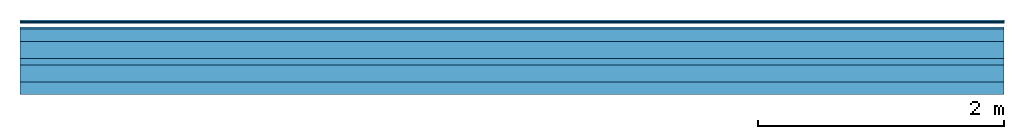
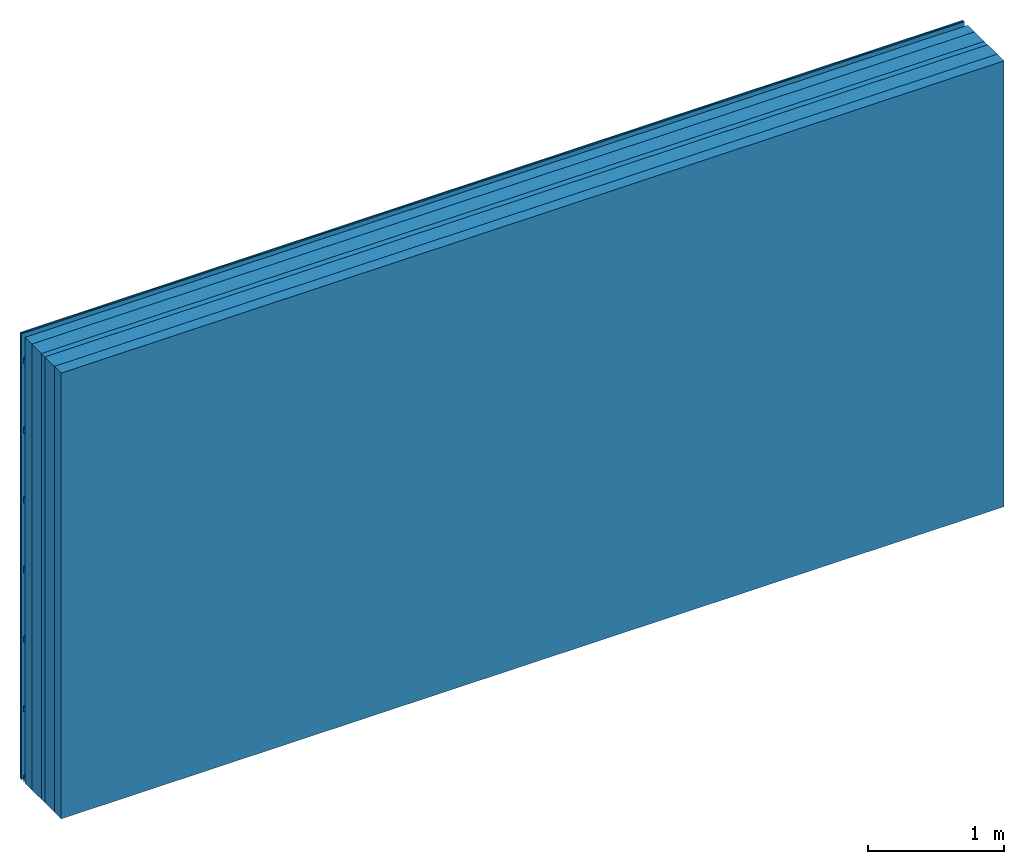
# One storey: 5 plates, 3 members, 1 element without a shape of its own.
"""IFC4 building model written with IfcOpenShell, lengths in metres."""

from ifc_helpers import new_model, si_unit, derived_unit, direction, frame, frame_2d, origin, origin_with_axes, place, context, project, spatial, polyline, rectangle, outline, extrude, material, layer, layer_set, type_object, element, aggregate, save


model = new_model("IFC4")

# Units and contexts
plan_context = context("Plan", 3, precision=1e-05, world=origin(), true_north=direction((0.0, 1.0)))
model_context = context("Model", 3, precision=1e-05, world=origin(), true_north=direction((0.0, 1.0)))
ifc_project = project(units=[si_unit("LENGTHUNIT", "METRE"), derived_unit("SOUNDPRESSUREUNIT", [(si_unit("PRESSUREUNIT", "PASCAL", prefix="MICRO"), 0)]), si_unit("ENERGYUNIT", "JOULE", prefix="MEGA"), si_unit("MASSUNIT", "GRAM", prefix="KILO"), derived_unit("THERMALTRANSMITTANCEUNIT", [(si_unit("POWERUNIT", "WATT"), 1), (si_unit("AREAUNIT", "SQUARE_METRE"), -1), (si_unit("THERMODYNAMICTEMPERATUREUNIT", "KELVIN"), -1)]), derived_unit("AREADENSITYUNIT", [(si_unit("MASSUNIT", "GRAM", prefix="KILO"), 1), (si_unit("AREAUNIT", "SQUARE_METRE"), -1)]), derived_unit("USERDEFINED", [(si_unit("ENERGYUNIT", "JOULE", prefix="MEGA"), 1), (si_unit("AREAUNIT", "SQUARE_METRE"), -1)])], contexts=[plan_context, model_context])

# Site, building, storey
site = spatial("IfcSite", under=ifc_project)
building_placement = place(None, origin())
building = spatial("IfcBuilding", under=site, at=building_placement)
storey_placement = place(building_placement, origin())
storey = spatial("IfcBuildingStorey", under=building, at=storey_placement)

# Wall, members, plates
ifc_material_1 = material(Name="Glued joints")
ifc_layer_1 = layer(ifc_material_1, 0.0, Name="Surface")
ifc_material_2 = material(Category="03.008")
ifc_layer_2 = layer(ifc_material_2, 0.0125, Name="Cover 2nd layer")
ifc_layer_3 = layer(ifc_material_2, 0.0125, Name="Cover 1st layer")
ifc_layer_4 = layer(None, 0.05, Name="Battens / profiles")
ifc_layer_5 = layer(None, 0.1, Name="Support")
ifc_material_3 = material(Name="of the art")
ifc_layer_6 = layer(ifc_material_3, 0.0, Name="Bond")
ifc_material_4 = material(Category="10.008")
ifc_layer_7 = layer(ifc_material_4, 0.14, Name="Intermediate insulation")
ifc_material_5 = material(Name="Air")
ifc_layer_8 = layer(ifc_material_5, 0.05, Name="Air gap")
ifc_layer_9 = layer(ifc_material_4, 0.14, Name="Intermediate insulation")
ifc_layer_10 = layer(ifc_material_3, 0.0, Name="Bond")
ifc_layer_11 = layer(None, 0.1, Name="Support")
ifc_layer_set = layer_set([ifc_layer_1, ifc_layer_2, ifc_layer_3, ifc_layer_4, ifc_layer_5, ifc_layer_6, ifc_layer_7, ifc_layer_8, ifc_layer_9, ifc_layer_10, ifc_layer_11])
wall_type = type_object("IfcWallType", Name="B9396", PredefinedType="NOTDEFINED", material=ifc_layer_set)
wall_placement = place(None, frame((0.0, 0.0, 0.0), z_axis=(0.0, -1.0, 0.0), x_axis=(1.0, 0.0, 0.0)))
wall = element("IfcWall", 1, at=wall_placement, inside=storey, type_object=wall_type, material=ifc_layer_set, Name="Wall #1")
ifc_material_6 = material()
member_1_placement = place(wall_placement, origin())
member_1 = element("IfcMember", 2, at=member_1_placement, material=ifc_material_6, Name="Battens / profiles", context=plan_context, shape_type="SweptSolid", body=[
    extrude(outline(polyline([(0.0, 0.0), (0.06, 0.0), (0.04, 0.02), (0.02, 0.02), (0.0, 0.0)])), frame((0.0, 0.0, 0.055), z_axis=(1.0, 0.0, 0.0), x_axis=(0.0, 1.0, 0.0)), (0.0, 0.0, 1.0), 8.0),
    extrude(outline(polyline([(0.0, 0.0), (0.06, 0.0), (0.04, 0.02), (0.02, 0.02), (0.0, 0.0)])), frame((0.0, 0.625, 0.055), z_axis=(1.0, 0.0, 0.0), x_axis=(0.0, 1.0, 0.0)), (0.0, 0.0, 1.0), 8.0),
    extrude(outline(polyline([(0.0, 0.0), (0.06, 0.0), (0.04, 0.02), (0.02, 0.02), (0.0, 0.0)])), frame((0.0, 1.25, 0.055), z_axis=(1.0, 0.0, 0.0), x_axis=(0.0, 1.0, 0.0)), (0.0, 0.0, 1.0), 8.0),
    extrude(outline(polyline([(0.0, 0.0), (0.06, 0.0), (0.04, 0.02), (0.02, 0.02), (0.0, 0.0)])), frame((0.0, 1.875, 0.055), z_axis=(1.0, 0.0, 0.0), x_axis=(0.0, 1.0, 0.0)), (0.0, 0.0, 1.0), 8.0),
    extrude(outline(polyline([(0.0, 0.0), (0.06, 0.0), (0.04, 0.02), (0.02, 0.02), (0.0, 0.0)])), frame((0.0, 2.5, 0.055), z_axis=(1.0, 0.0, 0.0), x_axis=(0.0, 1.0, 0.0)), (0.0, 0.0, 1.0), 8.0),
    extrude(outline(polyline([(0.0, 0.0), (0.06, 0.0), (0.04, 0.02), (0.02, 0.02), (0.0, 0.0)])), frame((0.0, 3.125, 0.055), z_axis=(1.0, 0.0, 0.0), x_axis=(0.0, 1.0, 0.0)), (0.0, 0.0, 1.0), 8.0),
    extrude(outline(polyline([(0.0, 0.0), (0.06, 0.0), (0.04, 0.02), (0.02, 0.02), (0.0, 0.0)])), frame((0.0, 3.75, 0.055), z_axis=(1.0, 0.0, 0.0), x_axis=(0.0, 1.0, 0.0)), (0.0, 0.0, 1.0), 8.0),
])
ifc_material_7 = material(Name="OSB")
member_2_placement = place(wall_placement, origin())
member_2 = element("IfcMember", 3, at=member_2_placement, material=ifc_material_7, Name="Support", context=plan_context, shape_type="SweptSolid", body=[
    extrude(rectangle(XDim=1.0, YDim=0.1, at=frame_2d((0.5, 0.05), x_axis=(1.0, 0.0))), frame((0.0, 4.0, 0.075), z_axis=(0.0, -1.0, 0.0), x_axis=(1.0, 0.0, 0.0)), (0.0, 0.0, 1.0), 4.0),
    extrude(rectangle(XDim=1.0, YDim=0.1, at=frame_2d((0.5, 0.05), x_axis=(1.0, 0.0))), frame((1.0, 4.0, 0.075), z_axis=(0.0, -1.0, 0.0), x_axis=(1.0, 0.0, 0.0)), (0.0, 0.0, 1.0), 4.0),
    extrude(rectangle(XDim=1.0, YDim=0.1, at=frame_2d((0.5, 0.05), x_axis=(1.0, 0.0))), frame((2.0, 4.0, 0.075), z_axis=(0.0, -1.0, 0.0), x_axis=(1.0, 0.0, 0.0)), (0.0, 0.0, 1.0), 4.0),
    extrude(rectangle(XDim=1.0, YDim=0.1, at=frame_2d((0.5, 0.05), x_axis=(1.0, 0.0))), frame((3.0, 4.0, 0.075), z_axis=(0.0, -1.0, 0.0), x_axis=(1.0, 0.0, 0.0)), (0.0, 0.0, 1.0), 4.0),
    extrude(rectangle(XDim=1.0, YDim=0.1, at=frame_2d((0.5, 0.05), x_axis=(1.0, 0.0))), frame((4.0, 4.0, 0.075), z_axis=(0.0, -1.0, 0.0), x_axis=(1.0, 0.0, 0.0)), (0.0, 0.0, 1.0), 4.0),
    extrude(rectangle(XDim=1.0, YDim=0.1, at=frame_2d((0.5, 0.05), x_axis=(1.0, 0.0))), frame((5.0, 4.0, 0.075), z_axis=(0.0, -1.0, 0.0), x_axis=(1.0, 0.0, 0.0)), (0.0, 0.0, 1.0), 4.0),
    extrude(rectangle(XDim=1.0, YDim=0.1, at=frame_2d((0.5, 0.05), x_axis=(1.0, 0.0))), frame((6.0, 4.0, 0.075), z_axis=(0.0, -1.0, 0.0), x_axis=(1.0, 0.0, 0.0)), (0.0, 0.0, 1.0), 4.0),
    extrude(rectangle(XDim=1.0, YDim=0.1, at=frame_2d((0.5, 0.05), x_axis=(1.0, 0.0))), frame((7.0, 4.0, 0.075), z_axis=(0.0, -1.0, 0.0), x_axis=(1.0, 0.0, 0.0)), (0.0, 0.0, 1.0), 4.0),
])
member_3_placement = place(wall_placement, origin())
member_3 = element("IfcMember", 4, at=member_3_placement, material=ifc_material_7, Name="Support", context=plan_context, shape_type="SweptSolid", body=[
    extrude(rectangle(XDim=1.0, YDim=0.1, at=frame_2d((0.5, 0.05), x_axis=(1.0, 0.0))), frame((0.0, 4.0, 0.505), z_axis=(0.0, -1.0, 0.0), x_axis=(1.0, 0.0, 0.0)), (0.0, 0.0, 1.0), 4.0),
    extrude(rectangle(XDim=1.0, YDim=0.1, at=frame_2d((0.5, 0.05), x_axis=(1.0, 0.0))), frame((1.0, 4.0, 0.505), z_axis=(0.0, -1.0, 0.0), x_axis=(1.0, 0.0, 0.0)), (0.0, 0.0, 1.0), 4.0),
    extrude(rectangle(XDim=1.0, YDim=0.1, at=frame_2d((0.5, 0.05), x_axis=(1.0, 0.0))), frame((2.0, 4.0, 0.505), z_axis=(0.0, -1.0, 0.0), x_axis=(1.0, 0.0, 0.0)), (0.0, 0.0, 1.0), 4.0),
    extrude(rectangle(XDim=1.0, YDim=0.1, at=frame_2d((0.5, 0.05), x_axis=(1.0, 0.0))), frame((3.0, 4.0, 0.505), z_axis=(0.0, -1.0, 0.0), x_axis=(1.0, 0.0, 0.0)), (0.0, 0.0, 1.0), 4.0),
    extrude(rectangle(XDim=1.0, YDim=0.1, at=frame_2d((0.5, 0.05), x_axis=(1.0, 0.0))), frame((4.0, 4.0, 0.505), z_axis=(0.0, -1.0, 0.0), x_axis=(1.0, 0.0, 0.0)), (0.0, 0.0, 1.0), 4.0),
    extrude(rectangle(XDim=1.0, YDim=0.1, at=frame_2d((0.5, 0.05), x_axis=(1.0, 0.0))), frame((5.0, 4.0, 0.505), z_axis=(0.0, -1.0, 0.0), x_axis=(1.0, 0.0, 0.0)), (0.0, 0.0, 1.0), 4.0),
    extrude(rectangle(XDim=1.0, YDim=0.1, at=frame_2d((0.5, 0.05), x_axis=(1.0, 0.0))), frame((6.0, 4.0, 0.505), z_axis=(0.0, -1.0, 0.0), x_axis=(1.0, 0.0, 0.0)), (0.0, 0.0, 1.0), 4.0),
    extrude(rectangle(XDim=1.0, YDim=0.1, at=frame_2d((0.5, 0.05), x_axis=(1.0, 0.0))), frame((7.0, 4.0, 0.505), z_axis=(0.0, -1.0, 0.0), x_axis=(1.0, 0.0, 0.0)), (0.0, 0.0, 1.0), 4.0),
])
plate_1_placement = place(wall_placement, origin())
plate_1 = element("IfcPlate", 5, at=plate_1_placement, material=ifc_material_2, Name="Cover 2nd layer", context=plan_context, shape_type="SweptSolid", body=[
    extrude(rectangle(XDim=8.0, YDim=4.0, at=frame_2d((4.0, 2.0), x_axis=(1.0, 0.0))), origin_with_axes(), (0.0, 0.0, 1.0), 0.0125),
])
plate_2_placement = place(wall_placement, origin())
plate_2 = element("IfcPlate", 6, at=plate_2_placement, material=ifc_material_2, Name="Cover 1st layer", context=plan_context, shape_type="SweptSolid", body=[
    extrude(rectangle(XDim=8.0, YDim=4.0, at=frame_2d((4.0, 2.0), x_axis=(1.0, 0.0))), frame((0.0, 0.0, 0.0125), z_axis=(0.0, 0.0, 1.0), x_axis=(1.0, 0.0, 0.0)), (0.0, 0.0, 1.0), 0.0125),
])
plate_3_placement = place(wall_placement, origin())
plate_3 = element("IfcPlate", 7, at=plate_3_placement, material=ifc_material_4, Name="Intermediate insulation", context=plan_context, shape_type="SweptSolid", body=[
    extrude(rectangle(XDim=8.0, YDim=4.0, at=frame_2d((4.0, 2.0), x_axis=(1.0, 0.0))), frame((0.0, 0.0, 0.175), z_axis=(0.0, 0.0, 1.0), x_axis=(1.0, 0.0, 0.0)), (0.0, 0.0, 1.0), 0.14),
])
plate_4_placement = place(wall_placement, origin())
plate_4 = element("IfcPlate", 8, at=plate_4_placement, material=ifc_material_5, Name="Air gap", context=plan_context, shape_type="SweptSolid", body=[
    extrude(rectangle(XDim=8.0, YDim=4.0, at=frame_2d((4.0, 2.0), x_axis=(1.0, 0.0))), frame((0.0, 0.0, 0.315), z_axis=(0.0, 0.0, 1.0), x_axis=(1.0, 0.0, 0.0)), (0.0, 0.0, 1.0), 0.05),
])
plate_5_placement = place(wall_placement, origin())
plate_5 = element("IfcPlate", 9, at=plate_5_placement, material=ifc_material_4, Name="Intermediate insulation", context=plan_context, shape_type="SweptSolid", body=[
    extrude(rectangle(XDim=8.0, YDim=4.0, at=frame_2d((4.0, 2.0), x_axis=(1.0, 0.0))), frame((0.0, 0.0, 0.365), z_axis=(0.0, 0.0, 1.0), x_axis=(1.0, 0.0, 0.0)), (0.0, 0.0, 1.0), 0.14),
])
aggregate(wall, [plate_1, plate_2, member_1, member_2, plate_3, plate_4, plate_5, member_3])

save(model, "model.ifc")
